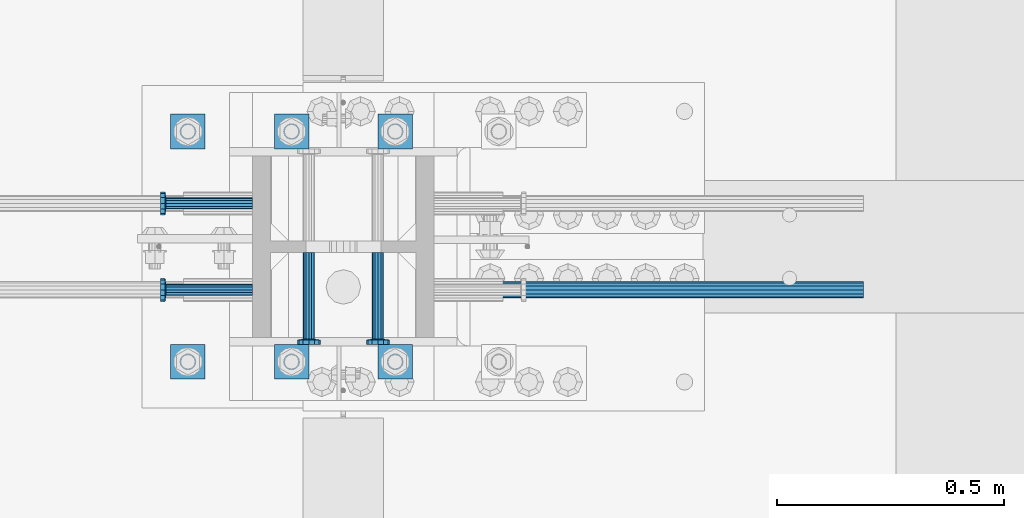
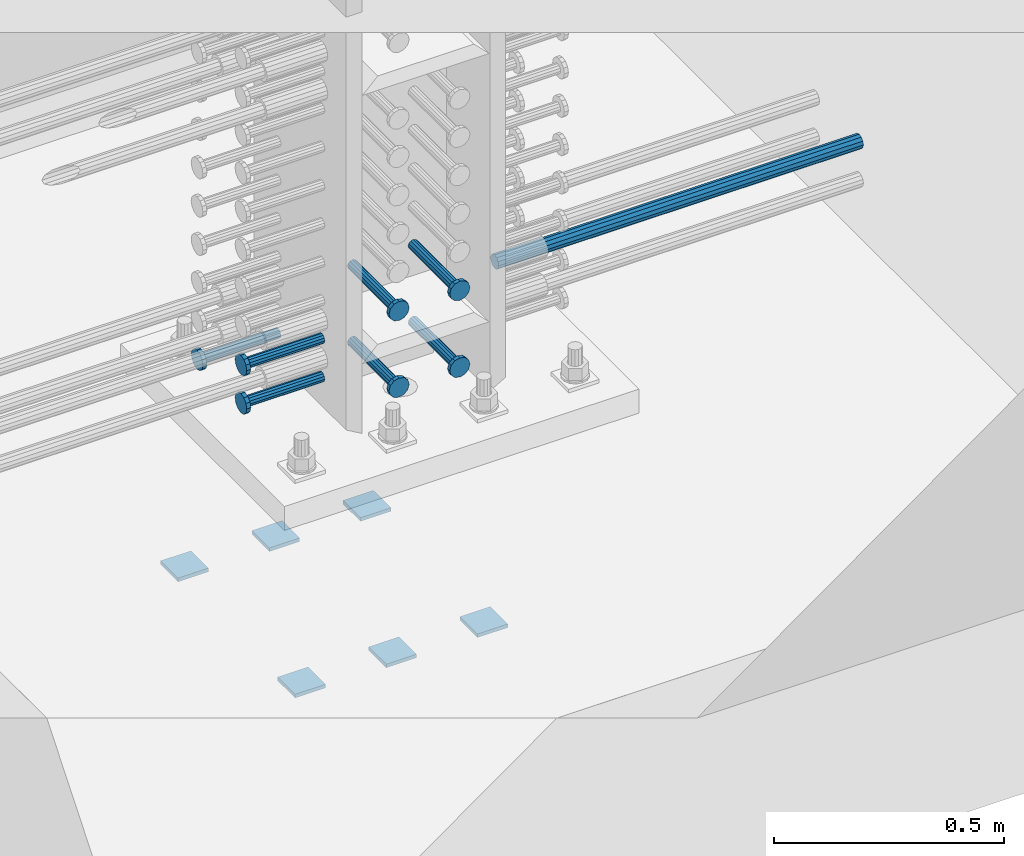
# One storey, part 1194 of 1763: 14 beams, 3 elements without a shape of their own.
"""IFC2X3 building model written with IfcOpenShell, lengths in millimetres."""

from ifc_helpers import new_model, si_unit, frame, origin_with_axes, place, context, subcontext, project, spatial, faceted_brep, material, type_object, element, aggregate, save


model = new_model("IFC2X3")

# Units and contexts
model_context = context("Model", 3, precision=1e-05, world=origin_with_axes())
body_context = subcontext(model_context, "Body", "Model", "MODEL_VIEW")
ifc_project = project(units=[si_unit("LENGTHUNIT", "METRE", prefix="MILLI"), si_unit("AREAUNIT", "SQUARE_METRE"), si_unit("VOLUMEUNIT", "CUBIC_METRE"), si_unit("MASSUNIT", "GRAM", prefix="KILO"), si_unit("TIMEUNIT", "SECOND"), si_unit("PLANEANGLEUNIT", "RADIAN"), si_unit("SOLIDANGLEUNIT", "STERADIAN"), si_unit("THERMODYNAMICTEMPERATUREUNIT", "DEGREE_CELSIUS"), si_unit("LUMINOUSINTENSITYUNIT", "LUMEN")], contexts=[model_context])

# Site, building, storey
site_placement = place(None, origin_with_axes())
site = spatial("IfcSite", under=ifc_project, at=site_placement, CompositionType="ELEMENT")
building_placement = place(site_placement, origin_with_axes())
building = spatial("IfcBuilding", under=site, at=building_placement, Name="Undefined", CompositionType="ELEMENT")
storey_placement = place(building_placement, origin_with_axes())
storey = spatial("IfcBuildingStorey", under=building, at=storey_placement, Name="Undefined", CompositionType="ELEMENT", Elevation=0.0)

# Assembly, beams
assembly_1_placement = place(storey_placement, origin_with_axes())
assembly_1 = element("IfcElementAssembly", 1, at=assembly_1_placement, inside=storey, Name="TEMPLATE", AssemblyPlace="NOTDEFINED", PredefinedType="RIGID_FRAME")
ifc_material_1 = material(Name="STEEL/A36")
beam_type_1 = type_object("IfcBeamType", PredefinedType="NOTDEFINED")
beam_1_placement = place(assembly_1_placement, frame((-72338.6372736972, 203.200000000843, 3348.0375), z_axis=(0.0, 1.0, 0.0), x_axis=(-1.0, 0.0, 0.0)))
beam_1 = element("IfcBeam", 2, at=beam_1_placement, type_object=beam_type_1, material=ifc_material_1, Name="WASHER PLATE", context=body_context, shape_type="Brep", body=[
    faceted_brep([(0.0, 4.76249999999709, -38.1000000000004), (0.0, 4.76249999999709, 38.1000000000004), (76.2000000000007, 4.76249999999982, 38.0999999999985), (76.2000000000007, 4.76249999999982, -38.0999999999985), (0.0, -4.76249999999709, 38.1000000000004), (76.2000000000007, -4.76249999999982, 38.0999999999985), (0.0, -4.76249999999709, -38.1000000000004), (76.2000000000007, -4.76249999999982, -38.0999999999985)], [[[0, 1, 2, 3]], [[1, 4, 5, 2]], [[4, 6, 7, 5]], [[6, 0, 3, 7]], [[5, 7, 3, 2]], [[6, 4, 1, 0]]]),
])
beam_2_placement = place(assembly_1_placement, frame((-72338.6372736972, 711.200000000843, 3348.0375), z_axis=(0.0, 1.0, 0.0), x_axis=(-1.0, 0.0, 0.0)))
beam_2 = element("IfcBeam", 3, at=beam_2_placement, type_object=beam_type_1, material=ifc_material_1, Name="WASHER PLATE", context=body_context, shape_type="Brep", body=[
    faceted_brep([(0.0, 4.76249999999709, -38.1000000000004), (0.0, 4.76249999999709, 38.1000000000004), (76.2000000000007, 4.76249999999982, 38.0999999999985), (76.2000000000007, 4.76249999999982, -38.0999999999985), (0.0, -4.76249999999709, 38.1000000000004), (76.2000000000007, -4.76249999999982, 38.0999999999985), (0.0, -4.76249999999709, -38.1000000000004), (76.2000000000007, -4.76249999999982, -38.0999999999985)], [[[0, 1, 2, 3]], [[1, 4, 5, 2]], [[4, 6, 7, 5]], [[6, 0, 3, 7]], [[5, 7, 3, 2]], [[6, 4, 1, 0]]]),
])
beam_3_placement = place(assembly_1_placement, frame((-72567.2372736972, 203.200000000843, 3348.0375), z_axis=(0.0, 1.0, 0.0), x_axis=(-1.0, 0.0, 0.0)))
beam_3 = element("IfcBeam", 4, at=beam_3_placement, type_object=beam_type_1, material=ifc_material_1, Name="WASHER PLATE", context=body_context, shape_type="Brep", body=[
    faceted_brep([(0.0, 4.76249999999709, -38.1000000000004), (0.0, 4.76249999999709, 38.1000000000004), (76.2000000000007, 4.76249999999982, 38.0999999999985), (76.2000000000007, 4.76249999999982, -38.0999999999985), (0.0, -4.76249999999709, 38.1000000000004), (76.2000000000007, -4.76249999999982, 38.0999999999985), (0.0, -4.76249999999709, -38.1000000000004), (76.2000000000007, -4.76249999999982, -38.0999999999985)], [[[0, 1, 2, 3]], [[1, 4, 5, 2]], [[4, 6, 7, 5]], [[6, 0, 3, 7]], [[5, 7, 3, 2]], [[6, 4, 1, 0]]]),
])
beam_4_placement = place(assembly_1_placement, frame((-72567.2372736972, 711.200000000843, 3348.0375), z_axis=(0.0, 1.0, 0.0), x_axis=(-1.0, 0.0, 0.0)))
beam_4 = element("IfcBeam", 5, at=beam_4_placement, type_object=beam_type_1, material=ifc_material_1, Name="WASHER PLATE", context=body_context, shape_type="Brep", body=[
    faceted_brep([(0.0, 4.76249999999709, -38.1000000000004), (0.0, 4.76249999999709, 38.1000000000004), (76.2000000000007, 4.76249999999982, 38.0999999999985), (76.2000000000007, 4.76249999999982, -38.0999999999985), (0.0, -4.76249999999709, 38.1000000000004), (76.2000000000007, -4.76249999999982, 38.0999999999985), (0.0, -4.76249999999709, -38.1000000000004), (76.2000000000007, -4.76249999999982, -38.0999999999985)], [[[0, 1, 2, 3]], [[1, 4, 5, 2]], [[4, 6, 7, 5]], [[6, 0, 3, 7]], [[5, 7, 3, 2]], [[6, 4, 1, 0]]]),
])
beam_5_placement = place(assembly_1_placement, frame((-72795.8372736972, 203.200000000843, 3348.0375), z_axis=(0.0, 1.0, 0.0), x_axis=(-1.0, 0.0, 0.0)))
beam_5 = element("IfcBeam", 6, at=beam_5_placement, type_object=beam_type_1, material=ifc_material_1, Name="WASHER PLATE", context=body_context, shape_type="Brep", body=[
    faceted_brep([(0.0, 4.76249999999709, -38.1000000000004), (0.0, 4.76249999999709, 38.1000000000004), (76.2000000000007, 4.76249999999982, 38.0999999999985), (76.2000000000007, 4.76249999999982, -38.0999999999985), (0.0, -4.76249999999709, 38.1000000000004), (76.2000000000007, -4.76249999999982, 38.0999999999985), (0.0, -4.76249999999709, -38.1000000000004), (76.2000000000007, -4.76249999999982, -38.0999999999985)], [[[0, 1, 2, 3]], [[1, 4, 5, 2]], [[4, 6, 7, 5]], [[6, 0, 3, 7]], [[5, 7, 3, 2]], [[6, 4, 1, 0]]]),
])
beam_6_placement = place(assembly_1_placement, frame((-72795.8372736972, 711.200000000843, 3348.0375), z_axis=(0.0, 1.0, 0.0), x_axis=(-1.0, 0.0, 0.0)))
beam_6 = element("IfcBeam", 7, at=beam_6_placement, type_object=beam_type_1, material=ifc_material_1, Name="WASHER PLATE", context=body_context, shape_type="Brep", body=[
    faceted_brep([(0.0, 4.76249999999709, -38.1000000000004), (0.0, 4.76249999999709, 38.1000000000004), (76.2000000000007, 4.76249999999982, 38.0999999999985), (76.2000000000007, 4.76249999999982, -38.0999999999985), (0.0, -4.76249999999709, 38.1000000000004), (76.2000000000007, -4.76249999999982, 38.0999999999985), (0.0, -4.76249999999709, -38.1000000000004), (76.2000000000007, -4.76249999999982, -38.0999999999985)], [[[0, 1, 2, 3]], [[1, 4, 5, 2]], [[4, 6, 7, 5]], [[6, 0, 3, 7]], [[5, 7, 3, 2]], [[6, 4, 1, 0]]]),
])
aggregate(assembly_1, [beam_1, beam_2, beam_3, beam_4, beam_5, beam_6])

# Assembly, beam
assembly_2_placement = place(storey_placement, origin_with_axes())
assembly_2 = element("IfcElementAssembly", 8, at=assembly_2_placement, inside=storey, Name="REBAR", AssemblyPlace="NOTDEFINED", PredefinedType="RIGID_FRAME")
ifc_material_2 = material(Name="STEEL/A706-GR.80")
beam_type_2 = type_object("IfcBeamType", Name="#11 REBAR", PredefinedType="NOTDEFINED")
beam_7_placement = place(assembly_2_placement, frame((-72258.2462736235, 361.949999999742, 4165.60000000003), z_axis=(0.0, 0.0, 1.0), x_axis=(1.0, 0.0, 0.0)))
beam_7 = element("IfcBeam", 9, at=beam_7_placement, type_object=beam_type_2, material=ifc_material_2, Name="REBAR", ObjectType="#11 REBAR", context=body_context, shape_type="Brep", body=[
    faceted_brep([(0.0, -17.9069999999992, 0.0), (0.0, -15.507916905568, -8.95349999999962), (914.400000001086, -15.507916905568, -8.95349999999962), (914.400000001086, -17.9069999999992, 0.0), (0.0, -8.95349999999962, -15.507916905568), (914.400000001086, -8.95349999999962, -15.507916905568), (0.0, 0.0, -17.9070000000002), (914.400000001086, 0.0, -17.9070000000002), (0.0, 8.95349999999962, -15.507916905568), (914.400000001086, 8.95349999999962, -15.507916905568), (0.0, 15.507916905568, -8.95349999999962), (914.400000001086, 15.507916905568, -8.95349999999962), (0.0, 17.9069999999992, 0.0), (914.400000001086, 17.9069999999992, 0.0), (0.0, 15.507916905568, 8.95349999999962), (914.400000001086, 15.507916905568, 8.95349999999962), (0.0, 8.95349999999962, 15.507916905568), (914.400000001086, 8.95349999999962, 15.507916905568), (0.0, 0.0, 17.9070000000002), (914.400000001086, 0.0, 17.9070000000002), (0.0, -8.95349999999962, 15.507916905568), (914.400000001086, -8.95349999999962, 15.507916905568), (0.0, -15.507916905568, 8.95349999999962), (914.400000001086, -15.507916905568, 8.95349999999962)], [[[0, 1, 2, 3]], [[1, 4, 5, 2]], [[4, 6, 7, 5]], [[6, 8, 9, 7]], [[8, 10, 11, 9]], [[10, 12, 13, 11]], [[12, 14, 15, 13]], [[14, 16, 17, 15]], [[16, 18, 19, 17]], [[18, 20, 21, 19]], [[20, 22, 23, 21]], [[22, 0, 3, 23]], [[5, 7, 9, 11, 13, 15, 17, 19, 21, 23, 3, 2]], [[22, 20, 18, 16, 14, 12, 10, 8, 6, 4, 1, 0]]]),
])
aggregate(assembly_2, [beam_7])

# Assembly, beams
assembly_3_placement = place(storey_placement, origin_with_axes())
assembly_3 = element("IfcElementAssembly", 10, at=assembly_3_placement, inside=storey, Name="COLUMN", AssemblyPlace="NOTDEFINED", PredefinedType="RIGID_FRAME")
ifc_material_3 = material(Name="STEEL/A108")
beam_type_3 = type_object("IfcBeamType", PredefinedType="NOTDEFINED")
beam_8_placement = place(assembly_3_placement, frame((-72691.0622736973, 361.950000000834, 4114.80000000002), z_axis=(0.0, 1.0, 0.0), x_axis=(-1.0, 0.0, 0.0)))
beam_8 = element("IfcBeam", 11, at=beam_8_placement, type_object=beam_type_3, material=ifc_material_3, Name="HEADED STUD ANCHOR", context=body_context, shape_type="Brep", body=[
    faceted_brep([(0.0, -12.6999999999971, -1.81898940354586e-12), (3.63797880709171e-12, -11.0, -6.34999990463257), (191.00799999576, -11.0, -6.34999990454889), (191.007999995752, -12.6999998092651, 8.36735125631094e-11), (7.27595761418343e-12, -6.34999990463257, -11.0), (191.00799999576, -6.34999990463257, -10.9999999999163), (3.63797880709171e-12, 0.0, -12.6999998092651), (191.00799999576, 0.0, -12.6999998091815), (7.27595761418343e-12, 6.34999990463257, -11.0), (191.00799999576, 6.34999990463257, -10.9999999999163), (3.63797880709171e-12, 11.0, -6.34999990463257), (191.00799999576, 11.0, -6.34999990454889), (0.0, 12.6999999999971, -1.81898940354586e-12), (191.007999995752, 12.6999998092651, 8.36735125631094e-11), (0.0, 11.0, 6.34999990463257), (191.007999995752, 11.0, 6.34999990471624), (-3.63797880709171e-12, 6.34999990463257, 11.0), (191.007999995749, 6.34999990463257, 11.0000000000837), (-3.63797880709171e-12, 0.0, 12.6999998092651), (191.007999995749, 0.0, 12.6999998093488), (-3.63797880709171e-12, -6.34999990463257, 11.0), (191.007999995749, -6.34999990463257, 11.0000000000837), (0.0, -11.0, 6.34999990463257), (191.007999995752, -11.0, 6.34999990471624), (193.039999995715, -22.0, -12.6999998091796), (193.039999995708, -25.3999996185303, 8.54925019666553e-11), (193.039999995719, -12.6999998092651, -21.9999999999145), (193.039999995719, 0.0, -25.3999996184448), (193.039999995719, 12.6999998092651, -21.9999999999145), (193.039999995715, 22.0, -12.6999998091796), (193.039999995708, 25.3999996185303, 8.54925019666553e-11), (193.039999995704, 22.0, 12.6999998093506), (193.039999995701, 12.6999998092651, 22.0000000000855), (193.039999995697, 0.0, 25.3999996186158), (193.039999995701, -12.6999998092651, 22.0000000000855), (193.039999995704, -22.0, 12.6999998093506), (203.199999995486, -22.0, -12.6999998091742), (203.199999995482, -25.3999996185303, 9.09494701772928e-11), (203.199999995493, -12.6999998092651, -21.9999999999091), (203.199999995493, 0.0, -25.3999996184393), (203.199999995493, 12.6999998092651, -21.9999999999091), (203.199999995486, 22.0, -12.6999998091742), (203.199999995482, 25.3999996185303, 9.09494701772928e-11), (203.199999995479, 22.0, 12.6999998093561), (203.199999995475, 12.6999998092651, 22.0000000000909), (203.199999995471, 0.0, 25.3999996186212), (203.199999995475, -12.6999998092651, 22.0000000000909), (203.199999995479, -22.0, 12.6999998093561)], [[[0, 1, 2, 3]], [[1, 4, 5, 2]], [[4, 6, 7, 5]], [[6, 8, 9, 7]], [[8, 10, 11, 9]], [[10, 12, 13, 11]], [[12, 14, 15, 13]], [[14, 16, 17, 15]], [[16, 18, 19, 17]], [[18, 20, 21, 19]], [[20, 22, 23, 21]], [[22, 0, 3, 23]], [[22, 20, 18, 16, 14, 12, 10, 8, 6, 4, 1, 0]], [[3, 2, 24, 25]], [[2, 5, 26, 24]], [[5, 7, 27, 26]], [[7, 9, 28, 27]], [[9, 11, 29, 28]], [[11, 13, 30, 29]], [[13, 15, 31, 30]], [[15, 17, 32, 31]], [[17, 19, 33, 32]], [[19, 21, 34, 33]], [[21, 23, 35, 34]], [[23, 3, 25, 35]], [[25, 24, 36, 37]], [[24, 26, 38, 36]], [[26, 27, 39, 38]], [[27, 28, 40, 39]], [[28, 29, 41, 40]], [[29, 30, 42, 41]], [[30, 31, 43, 42]], [[31, 32, 44, 43]], [[32, 33, 45, 44]], [[33, 34, 46, 45]], [[34, 35, 47, 46]], [[35, 25, 37, 47]], [[38, 39, 40, 41, 42, 43, 44, 45, 46, 47, 37, 36]]]),
])
beam_9_placement = place(assembly_3_placement, frame((-72691.0622049623, 361.950000000834, 4013.2), z_axis=(0.0, 1.0, 0.0), x_axis=(-1.0, 0.0, 0.0)))
beam_9 = element("IfcBeam", 12, at=beam_9_placement, type_object=beam_type_3, material=ifc_material_3, Name="HEADED STUD ANCHOR", context=body_context, shape_type="Brep", body=[
    faceted_brep([(0.0, -12.6999999999971, -1.81898940354586e-12), (3.63797880709171e-12, -11.0, -6.34999990463257), (191.00799999576, -11.0, -6.34999990454889), (191.007999995752, -12.6999998092651, 8.36735125631094e-11), (7.27595761418343e-12, -6.34999990463257, -11.0), (191.00799999576, -6.34999990463257, -10.9999999999163), (3.63797880709171e-12, 0.0, -12.6999998092651), (191.00799999576, 0.0, -12.6999998091815), (7.27595761418343e-12, 6.34999990463257, -11.0), (191.00799999576, 6.34999990463257, -10.9999999999163), (3.63797880709171e-12, 11.0, -6.34999990463257), (191.00799999576, 11.0, -6.34999990454889), (0.0, 12.6999999999971, -1.81898940354586e-12), (191.007999995752, 12.6999998092651, 8.36735125631094e-11), (0.0, 11.0, 6.34999990463257), (191.007999995752, 11.0, 6.34999990471624), (-3.63797880709171e-12, 6.34999990463257, 11.0), (191.007999995749, 6.34999990463257, 11.0000000000837), (-3.63797880709171e-12, 0.0, 12.6999998092651), (191.007999995749, 0.0, 12.6999998093488), (-3.63797880709171e-12, -6.34999990463257, 11.0), (191.007999995749, -6.34999990463257, 11.0000000000837), (0.0, -11.0, 6.34999990463257), (191.007999995752, -11.0, 6.34999990471624), (193.039999995715, -22.0, -12.6999998091796), (193.039999995708, -25.3999996185303, 8.54925019666553e-11), (193.039999995719, -12.6999998092651, -21.9999999999145), (193.039999995719, 0.0, -25.3999996184448), (193.039999995719, 12.6999998092651, -21.9999999999145), (193.039999995715, 22.0, -12.6999998091796), (193.039999995708, 25.3999996185303, 8.54925019666553e-11), (193.039999995704, 22.0, 12.6999998093506), (193.039999995701, 12.6999998092651, 22.0000000000855), (193.039999995697, 0.0, 25.3999996186158), (193.039999995701, -12.6999998092651, 22.0000000000855), (193.039999995704, -22.0, 12.6999998093506), (203.199999995486, -22.0, -12.6999998091742), (203.199999995482, -25.3999996185303, 9.09494701772928e-11), (203.199999995493, -12.6999998092651, -21.9999999999091), (203.199999995493, 0.0, -25.3999996184393), (203.199999995493, 12.6999998092651, -21.9999999999091), (203.199999995486, 22.0, -12.6999998091742), (203.199999995482, 25.3999996185303, 9.09494701772928e-11), (203.199999995479, 22.0, 12.6999998093561), (203.199999995475, 12.6999998092651, 22.0000000000909), (203.199999995471, 0.0, 25.3999996186212), (203.199999995475, -12.6999998092651, 22.0000000000909), (203.199999995479, -22.0, 12.6999998093561)], [[[0, 1, 2, 3]], [[1, 4, 5, 2]], [[4, 6, 7, 5]], [[6, 8, 9, 7]], [[8, 10, 11, 9]], [[10, 12, 13, 11]], [[12, 14, 15, 13]], [[14, 16, 17, 15]], [[16, 18, 19, 17]], [[18, 20, 21, 19]], [[20, 22, 23, 21]], [[22, 0, 3, 23]], [[22, 20, 18, 16, 14, 12, 10, 8, 6, 4, 1, 0]], [[3, 2, 24, 25]], [[2, 5, 26, 24]], [[5, 7, 27, 26]], [[7, 9, 28, 27]], [[9, 11, 29, 28]], [[11, 13, 30, 29]], [[13, 15, 31, 30]], [[15, 17, 32, 31]], [[17, 19, 33, 32]], [[19, 21, 34, 33]], [[21, 23, 35, 34]], [[23, 3, 25, 35]], [[25, 24, 36, 37]], [[24, 26, 38, 36]], [[26, 27, 39, 38]], [[27, 28, 40, 39]], [[28, 29, 41, 40]], [[29, 30, 42, 41]], [[30, 31, 43, 42]], [[31, 32, 44, 43]], [[32, 33, 45, 44]], [[33, 34, 46, 45]], [[34, 35, 47, 46]], [[35, 25, 37, 47]], [[38, 39, 40, 41, 42, 43, 44, 45, 46, 47, 37, 36]]]),
])
beam_10_placement = place(assembly_3_placement, frame((-72691.0621362268, 552.45000000066, 4013.2), z_axis=(0.0, 1.0, 0.0), x_axis=(-1.0, 0.0, 0.0)))
beam_10 = element("IfcBeam", 13, at=beam_10_placement, type_object=beam_type_3, material=ifc_material_3, Name="HEADED STUD ANCHOR", context=body_context, shape_type="Brep", body=[
    faceted_brep([(0.0, -12.6999999999971, -1.81898940354586e-12), (3.63797880709171e-12, -11.0, -6.34999990463257), (191.00799999576, -11.0, -6.34999990454889), (191.007999995752, -12.6999998092651, 8.36735125631094e-11), (7.27595761418343e-12, -6.34999990463257, -11.0), (191.00799999576, -6.34999990463257, -10.9999999999163), (3.63797880709171e-12, 0.0, -12.6999998092651), (191.00799999576, 0.0, -12.6999998091815), (7.27595761418343e-12, 6.34999990463257, -11.0), (191.00799999576, 6.34999990463257, -10.9999999999163), (3.63797880709171e-12, 11.0, -6.34999990463257), (191.00799999576, 11.0, -6.34999990454889), (0.0, 12.6999999999971, -1.81898940354586e-12), (191.007999995752, 12.6999998092651, 8.36735125631094e-11), (0.0, 11.0, 6.34999990463257), (191.007999995752, 11.0, 6.34999990471624), (-3.63797880709171e-12, 6.34999990463257, 11.0), (191.007999995749, 6.34999990463257, 11.0000000000837), (-3.63797880709171e-12, 0.0, 12.6999998092651), (191.007999995749, 0.0, 12.6999998093488), (-3.63797880709171e-12, -6.34999990463257, 11.0), (191.007999995749, -6.34999990463257, 11.0000000000837), (0.0, -11.0, 6.34999990463257), (191.007999995752, -11.0, 6.34999990471624), (193.039999995715, -22.0, -12.6999998091796), (193.039999995708, -25.3999996185303, 8.54925019666553e-11), (193.039999995719, -12.6999998092651, -21.9999999999145), (193.039999995719, 0.0, -25.3999996184448), (193.039999995719, 12.6999998092651, -21.9999999999145), (193.039999995715, 22.0, -12.6999998091796), (193.039999995708, 25.3999996185303, 8.54925019666553e-11), (193.039999995704, 22.0, 12.6999998093506), (193.039999995701, 12.6999998092651, 22.0000000000855), (193.039999995697, 0.0, 25.3999996186158), (193.039999995701, -12.6999998092651, 22.0000000000855), (193.039999995704, -22.0, 12.6999998093506), (203.199999995486, -22.0, -12.6999998091742), (203.199999995482, -25.3999996185303, 9.09494701772928e-11), (203.199999995493, -12.6999998092651, -21.9999999999091), (203.199999995493, 0.0, -25.3999996184393), (203.199999995493, 12.6999998092651, -21.9999999999091), (203.199999995486, 22.0, -12.6999998091742), (203.199999995482, 25.3999996185303, 9.09494701772928e-11), (203.199999995479, 22.0, 12.6999998093561), (203.199999995475, 12.6999998092651, 22.0000000000909), (203.199999995471, 0.0, 25.3999996186212), (203.199999995475, -12.6999998092651, 22.0000000000909), (203.199999995479, -22.0, 12.6999998093561)], [[[0, 1, 2, 3]], [[1, 4, 5, 2]], [[4, 6, 7, 5]], [[6, 8, 9, 7]], [[8, 10, 11, 9]], [[10, 12, 13, 11]], [[12, 14, 15, 13]], [[14, 16, 17, 15]], [[16, 18, 19, 17]], [[18, 20, 21, 19]], [[20, 22, 23, 21]], [[22, 0, 3, 23]], [[22, 20, 18, 16, 14, 12, 10, 8, 6, 4, 1, 0]], [[3, 2, 24, 25]], [[2, 5, 26, 24]], [[5, 7, 27, 26]], [[7, 9, 28, 27]], [[9, 11, 29, 28]], [[11, 13, 30, 29]], [[13, 15, 31, 30]], [[15, 17, 32, 31]], [[17, 19, 33, 32]], [[19, 21, 34, 33]], [[21, 23, 35, 34]], [[23, 3, 25, 35]], [[25, 24, 36, 37]], [[24, 26, 38, 36]], [[26, 27, 39, 38]], [[27, 28, 40, 39]], [[28, 29, 41, 40]], [[29, 30, 42, 41]], [[30, 31, 43, 42]], [[31, 32, 44, 43]], [[32, 33, 45, 44]], [[33, 34, 46, 45]], [[34, 35, 47, 46]], [[35, 25, 37, 47]], [[38, 39, 40, 41, 42, 43, 44, 45, 46, 47, 37, 36]]]),
])
beam_11_placement = place(assembly_3_placement, frame((-72567.2373420903, 444.499999886566, 4216.40000000002), z_axis=(1.0, 0.0, 0.0), x_axis=(0.0, -1.0, 0.0)))
beam_11 = element("IfcBeam", 14, at=beam_11_placement, type_object=beam_type_3, material=ifc_material_3, Name="HEADED STUD ANCHOR", context=body_context, shape_type="Brep", body=[
    faceted_brep([(0.0, -12.6999999999971, -1.81898940354586e-12), (3.63797880709171e-12, -11.0, -6.34999990463257), (191.00799999576, -11.0, -6.34999990454889), (191.007999995752, -12.6999998092651, 8.36735125631094e-11), (7.27595761418343e-12, -6.34999990463257, -11.0), (191.00799999576, -6.34999990463257, -10.9999999999163), (3.63797880709171e-12, 0.0, -12.6999998092651), (191.00799999576, 0.0, -12.6999998091815), (7.27595761418343e-12, 6.34999990463257, -11.0), (191.00799999576, 6.34999990463257, -10.9999999999163), (3.63797880709171e-12, 11.0, -6.34999990463257), (191.00799999576, 11.0, -6.34999990454889), (0.0, 12.6999999999971, -1.81898940354586e-12), (191.007999995752, 12.6999998092651, 8.36735125631094e-11), (0.0, 11.0, 6.34999990463257), (191.007999995752, 11.0, 6.34999990471624), (-3.63797880709171e-12, 6.34999990463257, 11.0), (191.007999995749, 6.34999990463257, 11.0000000000837), (-3.63797880709171e-12, 0.0, 12.6999998092651), (191.007999995749, 0.0, 12.6999998093488), (-3.63797880709171e-12, -6.34999990463257, 11.0), (191.007999995749, -6.34999990463257, 11.0000000000837), (0.0, -11.0, 6.34999990463257), (191.007999995752, -11.0, 6.34999990471624), (193.039999995715, -22.0, -12.6999998091796), (193.039999995708, -25.3999996185303, 8.54925019666553e-11), (193.039999995719, -12.6999998092651, -21.9999999999145), (193.039999995719, 0.0, -25.3999996184448), (193.039999995719, 12.6999998092651, -21.9999999999145), (193.039999995715, 22.0, -12.6999998091796), (193.039999995708, 25.3999996185303, 8.54925019666553e-11), (193.039999995704, 22.0, 12.6999998093506), (193.039999995701, 12.6999998092651, 22.0000000000855), (193.039999995697, 0.0, 25.3999996186158), (193.039999995701, -12.6999998092651, 22.0000000000855), (193.039999995704, -22.0, 12.6999998093506), (203.199999995486, -22.0, -12.6999998091742), (203.199999995482, -25.3999996185303, 9.09494701772928e-11), (203.199999995493, -12.6999998092651, -21.9999999999091), (203.199999995493, 0.0, -25.3999996184393), (203.199999995493, 12.6999998092651, -21.9999999999091), (203.199999995486, 22.0, -12.6999998091742), (203.199999995482, 25.3999996185303, 9.09494701772928e-11), (203.199999995479, 22.0, 12.6999998093561), (203.199999995475, 12.6999998092651, 22.0000000000909), (203.199999995471, 0.0, 25.3999996186212), (203.199999995475, -12.6999998092651, 22.0000000000909), (203.199999995479, -22.0, 12.6999998093561)], [[[0, 1, 2, 3]], [[1, 4, 5, 2]], [[4, 6, 7, 5]], [[6, 8, 9, 7]], [[8, 10, 11, 9]], [[10, 12, 13, 11]], [[12, 14, 15, 13]], [[14, 16, 17, 15]], [[16, 18, 19, 17]], [[18, 20, 21, 19]], [[20, 22, 23, 21]], [[22, 0, 3, 23]], [[22, 20, 18, 16, 14, 12, 10, 8, 6, 4, 1, 0]], [[3, 2, 24, 25]], [[2, 5, 26, 24]], [[5, 7, 27, 26]], [[7, 9, 28, 27]], [[9, 11, 29, 28]], [[11, 13, 30, 29]], [[13, 15, 31, 30]], [[15, 17, 32, 31]], [[17, 19, 33, 32]], [[19, 21, 34, 33]], [[21, 23, 35, 34]], [[23, 3, 25, 35]], [[25, 24, 36, 37]], [[24, 26, 38, 36]], [[26, 27, 39, 38]], [[27, 28, 40, 39]], [[28, 29, 41, 40]], [[29, 30, 42, 41]], [[30, 31, 43, 42]], [[31, 32, 44, 43]], [[32, 33, 45, 44]], [[33, 34, 46, 45]], [[34, 35, 47, 46]], [[35, 25, 37, 47]], [[38, 39, 40, 41, 42, 43, 44, 45, 46, 47, 37, 36]]]),
])
beam_12_placement = place(assembly_3_placement, frame((-72414.8373420912, 444.500000000843, 4216.40000000002), z_axis=(1.0, 0.0, 0.0), x_axis=(0.0, -1.0, 0.0)))
beam_12 = element("IfcBeam", 15, at=beam_12_placement, type_object=beam_type_3, material=ifc_material_3, Name="HEADED STUD ANCHOR", context=body_context, shape_type="Brep", body=[
    faceted_brep([(0.0, -12.6999999999971, -1.81898940354586e-12), (3.63797880709171e-12, -11.0, -6.34999990463257), (191.00799999576, -11.0, -6.34999990454889), (191.007999995752, -12.6999998092651, 8.36735125631094e-11), (7.27595761418343e-12, -6.34999990463257, -11.0), (191.00799999576, -6.34999990463257, -10.9999999999163), (3.63797880709171e-12, 0.0, -12.6999998092651), (191.00799999576, 0.0, -12.6999998091815), (7.27595761418343e-12, 6.34999990463257, -11.0), (191.00799999576, 6.34999990463257, -10.9999999999163), (3.63797880709171e-12, 11.0, -6.34999990463257), (191.00799999576, 11.0, -6.34999990454889), (0.0, 12.6999999999971, -1.81898940354586e-12), (191.007999995752, 12.6999998092651, 8.36735125631094e-11), (0.0, 11.0, 6.34999990463257), (191.007999995752, 11.0, 6.34999990471624), (-3.63797880709171e-12, 6.34999990463257, 11.0), (191.007999995749, 6.34999990463257, 11.0000000000837), (-3.63797880709171e-12, 0.0, 12.6999998092651), (191.007999995749, 0.0, 12.6999998093488), (-3.63797880709171e-12, -6.34999990463257, 11.0), (191.007999995749, -6.34999990463257, 11.0000000000837), (0.0, -11.0, 6.34999990463257), (191.007999995752, -11.0, 6.34999990471624), (193.039999995715, -22.0, -12.6999998091796), (193.039999995708, -25.3999996185303, 8.54925019666553e-11), (193.039999995719, -12.6999998092651, -21.9999999999145), (193.039999995719, 0.0, -25.3999996184448), (193.039999995719, 12.6999998092651, -21.9999999999145), (193.039999995715, 22.0, -12.6999998091796), (193.039999995708, 25.3999996185303, 8.54925019666553e-11), (193.039999995704, 22.0, 12.6999998093506), (193.039999995701, 12.6999998092651, 22.0000000000855), (193.039999995697, 0.0, 25.3999996186158), (193.039999995701, -12.6999998092651, 22.0000000000855), (193.039999995704, -22.0, 12.6999998093506), (203.199999995486, -22.0, -12.6999998091742), (203.199999995482, -25.3999996185303, 9.09494701772928e-11), (203.199999995493, -12.6999998092651, -21.9999999999091), (203.199999995493, 0.0, -25.3999996184393), (203.199999995493, 12.6999998092651, -21.9999999999091), (203.199999995486, 22.0, -12.6999998091742), (203.199999995482, 25.3999996185303, 9.09494701772928e-11), (203.199999995479, 22.0, 12.6999998093561), (203.199999995475, 12.6999998092651, 22.0000000000909), (203.199999995471, 0.0, 25.3999996186212), (203.199999995475, -12.6999998092651, 22.0000000000909), (203.199999995479, -22.0, 12.6999998093561)], [[[0, 1, 2, 3]], [[1, 4, 5, 2]], [[4, 6, 7, 5]], [[6, 8, 9, 7]], [[8, 10, 11, 9]], [[10, 12, 13, 11]], [[12, 14, 15, 13]], [[14, 16, 17, 15]], [[16, 18, 19, 17]], [[18, 20, 21, 19]], [[20, 22, 23, 21]], [[22, 0, 3, 23]], [[22, 20, 18, 16, 14, 12, 10, 8, 6, 4, 1, 0]], [[3, 2, 24, 25]], [[2, 5, 26, 24]], [[5, 7, 27, 26]], [[7, 9, 28, 27]], [[9, 11, 29, 28]], [[11, 13, 30, 29]], [[13, 15, 31, 30]], [[15, 17, 32, 31]], [[17, 19, 33, 32]], [[19, 21, 34, 33]], [[21, 23, 35, 34]], [[23, 3, 25, 35]], [[25, 24, 36, 37]], [[24, 26, 38, 36]], [[26, 27, 39, 38]], [[27, 28, 40, 39]], [[28, 29, 41, 40]], [[29, 30, 42, 41]], [[30, 31, 43, 42]], [[31, 32, 44, 43]], [[32, 33, 45, 44]], [[33, 34, 46, 45]], [[34, 35, 47, 46]], [[35, 25, 37, 47]], [[38, 39, 40, 41, 42, 43, 44, 45, 46, 47, 37, 36]]]),
])
beam_13_placement = place(assembly_3_placement, frame((-72567.2372733553, 444.499999886566, 4013.2), z_axis=(1.0, 0.0, 0.0), x_axis=(0.0, -1.0, 0.0)))
beam_13 = element("IfcBeam", 16, at=beam_13_placement, type_object=beam_type_3, material=ifc_material_3, Name="HEADED STUD ANCHOR", context=body_context, shape_type="Brep", body=[
    faceted_brep([(0.0, -12.6999999999971, -1.81898940354586e-12), (3.63797880709171e-12, -11.0, -6.34999990463257), (191.00799999576, -11.0, -6.34999990454889), (191.007999995752, -12.6999998092651, 8.36735125631094e-11), (7.27595761418343e-12, -6.34999990463257, -11.0), (191.00799999576, -6.34999990463257, -10.9999999999163), (3.63797880709171e-12, 0.0, -12.6999998092651), (191.00799999576, 0.0, -12.6999998091815), (7.27595761418343e-12, 6.34999990463257, -11.0), (191.00799999576, 6.34999990463257, -10.9999999999163), (3.63797880709171e-12, 11.0, -6.34999990463257), (191.00799999576, 11.0, -6.34999990454889), (0.0, 12.6999999999971, -1.81898940354586e-12), (191.007999995752, 12.6999998092651, 8.36735125631094e-11), (0.0, 11.0, 6.34999990463257), (191.007999995752, 11.0, 6.34999990471624), (-3.63797880709171e-12, 6.34999990463257, 11.0), (191.007999995749, 6.34999990463257, 11.0000000000837), (-3.63797880709171e-12, 0.0, 12.6999998092651), (191.007999995749, 0.0, 12.6999998093488), (-3.63797880709171e-12, -6.34999990463257, 11.0), (191.007999995749, -6.34999990463257, 11.0000000000837), (0.0, -11.0, 6.34999990463257), (191.007999995752, -11.0, 6.34999990471624), (193.039999995715, -22.0, -12.6999998091796), (193.039999995708, -25.3999996185303, 8.54925019666553e-11), (193.039999995719, -12.6999998092651, -21.9999999999145), (193.039999995719, 0.0, -25.3999996184448), (193.039999995719, 12.6999998092651, -21.9999999999145), (193.039999995715, 22.0, -12.6999998091796), (193.039999995708, 25.3999996185303, 8.54925019666553e-11), (193.039999995704, 22.0, 12.6999998093506), (193.039999995701, 12.6999998092651, 22.0000000000855), (193.039999995697, 0.0, 25.3999996186158), (193.039999995701, -12.6999998092651, 22.0000000000855), (193.039999995704, -22.0, 12.6999998093506), (203.199999995486, -22.0, -12.6999998091742), (203.199999995482, -25.3999996185303, 9.09494701772928e-11), (203.199999995493, -12.6999998092651, -21.9999999999091), (203.199999995493, 0.0, -25.3999996184393), (203.199999995493, 12.6999998092651, -21.9999999999091), (203.199999995486, 22.0, -12.6999998091742), (203.199999995482, 25.3999996185303, 9.09494701772928e-11), (203.199999995479, 22.0, 12.6999998093561), (203.199999995475, 12.6999998092651, 22.0000000000909), (203.199999995471, 0.0, 25.3999996186212), (203.199999995475, -12.6999998092651, 22.0000000000909), (203.199999995479, -22.0, 12.6999998093561)], [[[0, 1, 2, 3]], [[1, 4, 5, 2]], [[4, 6, 7, 5]], [[6, 8, 9, 7]], [[8, 10, 11, 9]], [[10, 12, 13, 11]], [[12, 14, 15, 13]], [[14, 16, 17, 15]], [[16, 18, 19, 17]], [[18, 20, 21, 19]], [[20, 22, 23, 21]], [[22, 0, 3, 23]], [[22, 20, 18, 16, 14, 12, 10, 8, 6, 4, 1, 0]], [[3, 2, 24, 25]], [[2, 5, 26, 24]], [[5, 7, 27, 26]], [[7, 9, 28, 27]], [[9, 11, 29, 28]], [[11, 13, 30, 29]], [[13, 15, 31, 30]], [[15, 17, 32, 31]], [[17, 19, 33, 32]], [[19, 21, 34, 33]], [[21, 23, 35, 34]], [[23, 3, 25, 35]], [[25, 24, 36, 37]], [[24, 26, 38, 36]], [[26, 27, 39, 38]], [[27, 28, 40, 39]], [[28, 29, 41, 40]], [[29, 30, 42, 41]], [[30, 31, 43, 42]], [[31, 32, 44, 43]], [[32, 33, 45, 44]], [[33, 34, 46, 45]], [[34, 35, 47, 46]], [[35, 25, 37, 47]], [[38, 39, 40, 41, 42, 43, 44, 45, 46, 47, 37, 36]]]),
])
beam_14_placement = place(assembly_3_placement, frame((-72414.8372733562, 444.500000000843, 4013.2), z_axis=(1.0, 0.0, 0.0), x_axis=(0.0, -1.0, 0.0)))
beam_14 = element("IfcBeam", 17, at=beam_14_placement, type_object=beam_type_3, material=ifc_material_3, Name="HEADED STUD ANCHOR", context=body_context, shape_type="Brep", body=[
    faceted_brep([(0.0, -12.6999999999971, -1.81898940354586e-12), (3.63797880709171e-12, -11.0, -6.34999990463257), (191.00799999576, -11.0, -6.34999990454889), (191.007999995752, -12.6999998092651, 8.36735125631094e-11), (7.27595761418343e-12, -6.34999990463257, -11.0), (191.00799999576, -6.34999990463257, -10.9999999999163), (3.63797880709171e-12, 0.0, -12.6999998092651), (191.00799999576, 0.0, -12.6999998091815), (7.27595761418343e-12, 6.34999990463257, -11.0), (191.00799999576, 6.34999990463257, -10.9999999999163), (3.63797880709171e-12, 11.0, -6.34999990463257), (191.00799999576, 11.0, -6.34999990454889), (0.0, 12.6999999999971, -1.81898940354586e-12), (191.007999995752, 12.6999998092651, 8.36735125631094e-11), (0.0, 11.0, 6.34999990463257), (191.007999995752, 11.0, 6.34999990471624), (-3.63797880709171e-12, 6.34999990463257, 11.0), (191.007999995749, 6.34999990463257, 11.0000000000837), (-3.63797880709171e-12, 0.0, 12.6999998092651), (191.007999995749, 0.0, 12.6999998093488), (-3.63797880709171e-12, -6.34999990463257, 11.0), (191.007999995749, -6.34999990463257, 11.0000000000837), (0.0, -11.0, 6.34999990463257), (191.007999995752, -11.0, 6.34999990471624), (193.039999995715, -22.0, -12.6999998091796), (193.039999995708, -25.3999996185303, 8.54925019666553e-11), (193.039999995719, -12.6999998092651, -21.9999999999145), (193.039999995719, 0.0, -25.3999996184448), (193.039999995719, 12.6999998092651, -21.9999999999145), (193.039999995715, 22.0, -12.6999998091796), (193.039999995708, 25.3999996185303, 8.54925019666553e-11), (193.039999995704, 22.0, 12.6999998093506), (193.039999995701, 12.6999998092651, 22.0000000000855), (193.039999995697, 0.0, 25.3999996186158), (193.039999995701, -12.6999998092651, 22.0000000000855), (193.039999995704, -22.0, 12.6999998093506), (203.199999995486, -22.0, -12.6999998091742), (203.199999995482, -25.3999996185303, 9.09494701772928e-11), (203.199999995493, -12.6999998092651, -21.9999999999091), (203.199999995493, 0.0, -25.3999996184393), (203.199999995493, 12.6999998092651, -21.9999999999091), (203.199999995486, 22.0, -12.6999998091742), (203.199999995482, 25.3999996185303, 9.09494701772928e-11), (203.199999995479, 22.0, 12.6999998093561), (203.199999995475, 12.6999998092651, 22.0000000000909), (203.199999995471, 0.0, 25.3999996186212), (203.199999995475, -12.6999998092651, 22.0000000000909), (203.199999995479, -22.0, 12.6999998093561)], [[[0, 1, 2, 3]], [[1, 4, 5, 2]], [[4, 6, 7, 5]], [[6, 8, 9, 7]], [[8, 10, 11, 9]], [[10, 12, 13, 11]], [[12, 14, 15, 13]], [[14, 16, 17, 15]], [[16, 18, 19, 17]], [[18, 20, 21, 19]], [[20, 22, 23, 21]], [[22, 0, 3, 23]], [[22, 20, 18, 16, 14, 12, 10, 8, 6, 4, 1, 0]], [[3, 2, 24, 25]], [[2, 5, 26, 24]], [[5, 7, 27, 26]], [[7, 9, 28, 27]], [[9, 11, 29, 28]], [[11, 13, 30, 29]], [[13, 15, 31, 30]], [[15, 17, 32, 31]], [[17, 19, 33, 32]], [[19, 21, 34, 33]], [[21, 23, 35, 34]], [[23, 3, 25, 35]], [[25, 24, 36, 37]], [[24, 26, 38, 36]], [[26, 27, 39, 38]], [[27, 28, 40, 39]], [[28, 29, 41, 40]], [[29, 30, 42, 41]], [[30, 31, 43, 42]], [[31, 32, 44, 43]], [[32, 33, 45, 44]], [[33, 34, 46, 45]], [[34, 35, 47, 46]], [[35, 25, 37, 47]], [[38, 39, 40, 41, 42, 43, 44, 45, 46, 47, 37, 36]]]),
])
aggregate(assembly_3, [beam_8, beam_9, beam_10, beam_11, beam_12, beam_13, beam_14])

save(model, "model.ifc")
